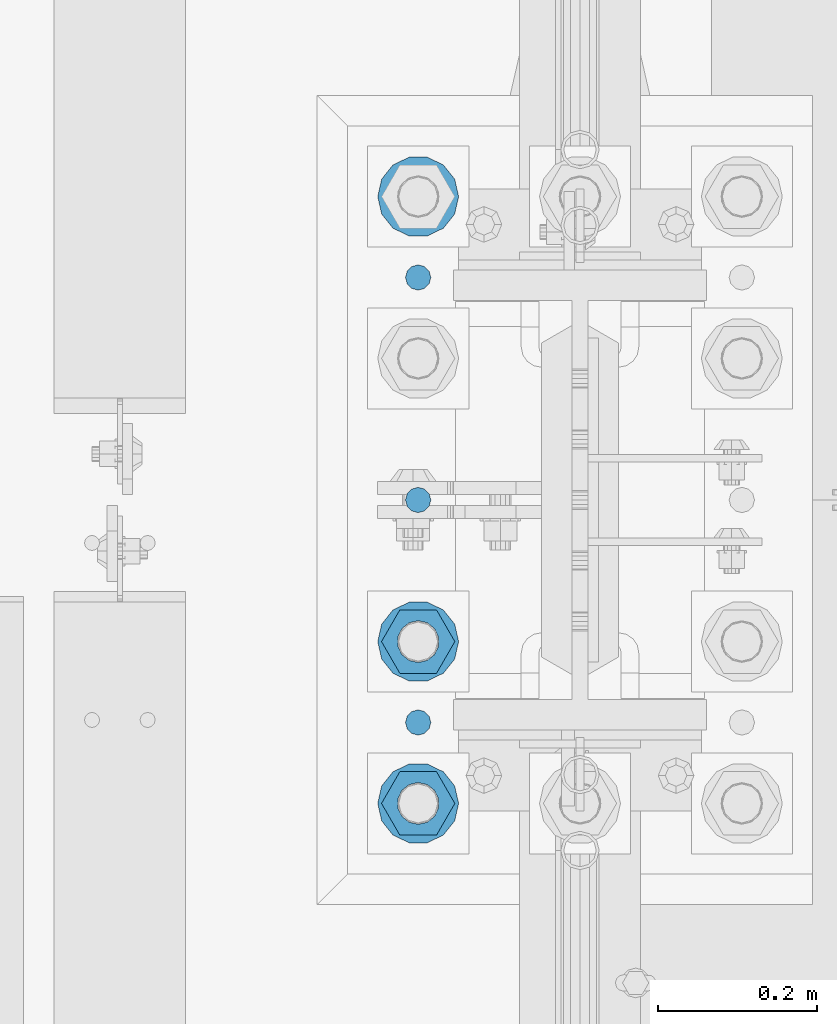
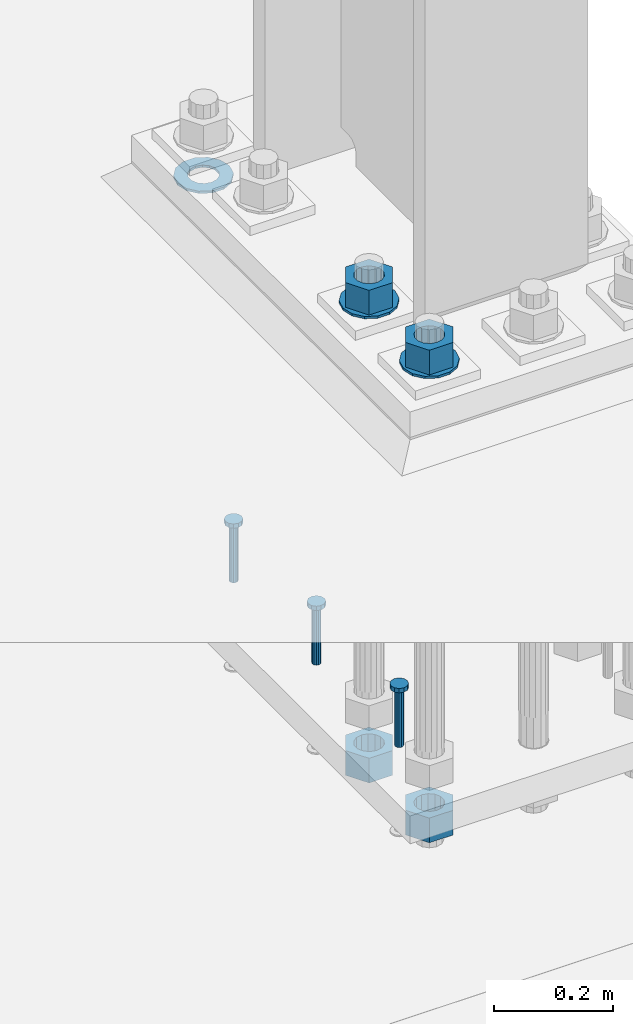
# One storey, part 838 of 1876: 10 columns, 1 element without a shape of its own.
"""IFC2X3 building model written with IfcOpenShell, lengths in millimetres."""

from ifc_helpers import new_model, si_unit, frame, origin_with_axes, place, context, subcontext, project, spatial, faceted_brep, material, type_object, element, aggregate, save


model = new_model("IFC2X3")

# Units and contexts
model_context = context("Model", 3, precision=1e-05, world=origin_with_axes())
body_context = subcontext(model_context, "Body", "Model", "MODEL_VIEW")
ifc_project = project(units=[si_unit("LENGTHUNIT", "METRE", prefix="MILLI"), si_unit("AREAUNIT", "SQUARE_METRE"), si_unit("VOLUMEUNIT", "CUBIC_METRE"), si_unit("MASSUNIT", "GRAM", prefix="KILO"), si_unit("TIMEUNIT", "SECOND"), si_unit("PLANEANGLEUNIT", "RADIAN"), si_unit("SOLIDANGLEUNIT", "STERADIAN"), si_unit("THERMODYNAMICTEMPERATUREUNIT", "DEGREE_CELSIUS"), si_unit("LUMINOUSINTENSITYUNIT", "LUMEN")], contexts=[model_context])

# Site, building, storey
site_placement = place(None, origin_with_axes())
site = spatial("IfcSite", under=ifc_project, at=site_placement, CompositionType="ELEMENT")
building_placement = place(site_placement, origin_with_axes())
building = spatial("IfcBuilding", under=site, at=building_placement, Name="Undefined", CompositionType="ELEMENT")
storey_placement = place(building_placement, origin_with_axes())
storey = spatial("IfcBuildingStorey", under=building, at=storey_placement, Name="Undefined", CompositionType="ELEMENT", Elevation=0.0)

# Assembly, columns
assembly_placement = place(storey_placement, origin_with_axes())
assembly = element("IfcElementAssembly", 1, at=assembly_placement, inside=storey, Name="TEMPLATE", AssemblyPlace="NOTDEFINED", PredefinedType="RIGID_FRAME")
ifc_material_1 = material(Name="STEEL/F436")
column_type_1 = type_object("IfcColumnType", Name="2_WASHER", PredefinedType="NOTDEFINED")
column_1_placement = place(assembly_placement, frame((7416.8, 1905.0, 38.1), z_axis=(0.0, -1.0, 0.0), x_axis=(0.0, 0.0, -1.0)))
column_1 = element("IfcColumn", 2, at=column_1_placement, type_object=column_type_1, material=ifc_material_1, Name="WASHER", ObjectType="2_WASHER", context=body_context, shape_type="Brep", body=[
    faceted_brep([(0.0, -50.7999992370605, 9.09494701772928e-13), (0.0, -45.7692178020588, -22.0412936161442), (4.7625, -45.7692178020588, -22.0412936161442), (4.7625, -50.7999992370605, 9.09494701772928e-13), (0.0, -31.6732814587394, -39.7170387128856), (4.7625, -31.6732814587394, -39.7170387128856), (0.0, -11.3040632752118, -49.5263371950259), (4.7625, -11.3040632752118, -49.5263371950259), (0.0, 11.30406327521, -49.5263371950264), (4.7625, 11.30406327521, -49.5263371950264), (0.0, 31.6732814587385, -39.7170387128867), (4.7625, 31.6732814587385, -39.7170387128867), (0.0, 45.7692178020579, -22.041293616146), (4.7625, 45.7692178020579, -22.041293616146), (0.0, 50.7999992370605, -9.09494701772928e-13), (4.7625, 50.7999992370605, -9.09494701772928e-13), (0.0, 45.7692178020588, 22.0412936161442), (4.7625, 45.7692178020588, 22.0412936161442), (0.0, 31.6732814587394, 39.7170387128856), (4.7625, 31.6732814587394, 39.7170387128856), (0.0, 11.3040632752118, 49.5263371950259), (4.7625, 11.3040632752118, 49.5263371950259), (0.0, -11.30406327521, 49.5263371950264), (4.7625, -11.30406327521, 49.5263371950264), (0.0, -31.6732814587385, 39.7170387128867), (4.7625, -31.6732814587385, 39.7170387128867), (0.0, -45.7692178020579, 22.041293616146), (4.7625, -45.7692178020579, 22.041293616146), (0.0, 0.0, 26.9869995117188), (0.0, 11.7093983825444, 24.3146012721213), (4.7625, 11.7093983825444, 24.3146012721213), (4.7625, 0.0, 26.9869995117188), (0.0, 21.0996520289491, 16.8262864224157), (4.7625, 21.0996520289491, 16.8262864224157), (0.0, 26.3108629296712, 6.00524193584533), (4.7625, 26.3108629296712, 6.00524193584533), (0.0, 26.3108629296712, -6.00524193584533), (4.7625, 26.3108629296712, -6.00524193584533), (0.0, 21.0996520289491, -16.8262864224157), (4.7625, 21.0996520289491, -16.8262864224157), (0.0, 11.7093983825444, -24.3146012721213), (4.7625, 11.7093983825444, -24.3146012721213), (0.0, 0.0, -26.9869995117188), (4.7625, 0.0, -26.9869995117188), (0.0, -11.7093983825444, -24.3146012721213), (4.7625, -11.7093983825444, -24.3146012721213), (0.0, -21.0996520289491, -16.8262864224157), (4.7625, -21.0996520289491, -16.8262864224157), (0.0, -26.3108629296712, -6.00524193584533), (4.7625, -26.3108629296712, -6.00524193584533), (0.0, -26.3108629296712, 6.00524193584533), (4.7625, -26.3108629296712, 6.00524193584533), (0.0, -21.0996520289491, 16.8262864224157), (4.7625, -21.0996520289491, 16.8262864224157), (0.0, -11.7093983825444, 24.3146012721213), (4.7625, -11.7093983825444, 24.3146012721213)], [[[0, 1, 2, 3]], [[1, 4, 5, 2]], [[4, 6, 7, 5]], [[6, 8, 9, 7]], [[8, 10, 11, 9]], [[10, 12, 13, 11]], [[12, 14, 15, 13]], [[14, 16, 17, 15]], [[16, 18, 19, 17]], [[18, 20, 21, 19]], [[20, 22, 23, 21]], [[22, 24, 25, 23]], [[24, 26, 27, 25]], [[26, 0, 3, 27]], [[28, 29, 30, 31]], [[29, 32, 33, 30]], [[32, 34, 35, 33]], [[34, 36, 37, 35]], [[36, 38, 39, 37]], [[38, 40, 41, 39]], [[40, 42, 43, 41]], [[42, 44, 45, 43]], [[44, 46, 47, 45]], [[46, 48, 49, 47]], [[48, 50, 51, 49]], [[50, 52, 53, 51]], [[52, 54, 55, 53]], [[54, 28, 31, 55]], [[5, 7, 9, 11, 13, 15, 17, 19, 21, 23, 25, 27, 3, 2], [33, 35, 37, 39, 41, 43, 45, 47, 49, 51, 53, 55, 31, 30]], [[26, 24, 22, 20, 18, 16, 14, 12, 10, 8, 6, 4, 1, 0], [54, 52, 50, 48, 46, 44, 42, 40, 38, 36, 34, 32, 29, 28]]]),
])
column_2_placement = place(assembly_placement, frame((7416.8, 1143.0, 119.0625), z_axis=(0.0, -1.0, 0.0), x_axis=(0.0, 0.0, -1.0)))
column_2 = element("IfcColumn", 3, at=column_2_placement, type_object=column_type_1, material=ifc_material_1, Name="WASHER", ObjectType="2_WASHER", context=body_context, shape_type="Brep", body=[
    faceted_brep([(0.0, -50.7999992370605, 9.09494701772928e-13), (0.0, -45.7692178020588, -22.0412936161442), (4.7625, -45.7692178020588, -22.0412936161442), (4.7625, -50.7999992370605, 9.09494701772928e-13), (0.0, -31.6732814587394, -39.7170387128856), (4.7625, -31.6732814587394, -39.7170387128856), (0.0, -11.3040632752118, -49.5263371950259), (4.7625, -11.3040632752118, -49.5263371950259), (0.0, 11.30406327521, -49.5263371950264), (4.7625, 11.30406327521, -49.5263371950264), (0.0, 31.6732814587385, -39.7170387128867), (4.7625, 31.6732814587385, -39.7170387128867), (0.0, 45.7692178020579, -22.041293616146), (4.7625, 45.7692178020579, -22.041293616146), (0.0, 50.7999992370605, -9.09494701772928e-13), (4.7625, 50.7999992370605, -9.09494701772928e-13), (0.0, 45.7692178020588, 22.0412936161442), (4.7625, 45.7692178020588, 22.0412936161442), (0.0, 31.6732814587394, 39.7170387128856), (4.7625, 31.6732814587394, 39.7170387128856), (0.0, 11.3040632752118, 49.5263371950259), (4.7625, 11.3040632752118, 49.5263371950259), (0.0, -11.30406327521, 49.5263371950264), (4.7625, -11.30406327521, 49.5263371950264), (0.0, -31.6732814587385, 39.7170387128867), (4.7625, -31.6732814587385, 39.7170387128867), (0.0, -45.7692178020579, 22.041293616146), (4.7625, -45.7692178020579, 22.041293616146), (0.0, 0.0, 26.9869995117188), (0.0, 11.7093983825444, 24.3146012721213), (4.7625, 11.7093983825444, 24.3146012721213), (4.7625, 0.0, 26.9869995117188), (0.0, 21.0996520289491, 16.8262864224157), (4.7625, 21.0996520289491, 16.8262864224157), (0.0, 26.3108629296712, 6.00524193584533), (4.7625, 26.3108629296712, 6.00524193584533), (0.0, 26.3108629296712, -6.00524193584533), (4.7625, 26.3108629296712, -6.00524193584533), (0.0, 21.0996520289491, -16.8262864224157), (4.7625, 21.0996520289491, -16.8262864224157), (0.0, 11.7093983825444, -24.3146012721213), (4.7625, 11.7093983825444, -24.3146012721213), (0.0, 0.0, -26.9869995117188), (4.7625, 0.0, -26.9869995117188), (0.0, -11.7093983825444, -24.3146012721213), (4.7625, -11.7093983825444, -24.3146012721213), (0.0, -21.0996520289491, -16.8262864224157), (4.7625, -21.0996520289491, -16.8262864224157), (0.0, -26.3108629296712, -6.00524193584533), (4.7625, -26.3108629296712, -6.00524193584533), (0.0, -26.3108629296712, 6.00524193584533), (4.7625, -26.3108629296712, 6.00524193584533), (0.0, -21.0996520289491, 16.8262864224157), (4.7625, -21.0996520289491, 16.8262864224157), (0.0, -11.7093983825444, 24.3146012721213), (4.7625, -11.7093983825444, 24.3146012721213)], [[[0, 1, 2, 3]], [[1, 4, 5, 2]], [[4, 6, 7, 5]], [[6, 8, 9, 7]], [[8, 10, 11, 9]], [[10, 12, 13, 11]], [[12, 14, 15, 13]], [[14, 16, 17, 15]], [[16, 18, 19, 17]], [[18, 20, 21, 19]], [[20, 22, 23, 21]], [[22, 24, 25, 23]], [[24, 26, 27, 25]], [[26, 0, 3, 27]], [[28, 29, 30, 31]], [[29, 32, 33, 30]], [[32, 34, 35, 33]], [[34, 36, 37, 35]], [[36, 38, 39, 37]], [[38, 40, 41, 39]], [[40, 42, 43, 41]], [[42, 44, 45, 43]], [[44, 46, 47, 45]], [[46, 48, 49, 47]], [[48, 50, 51, 49]], [[50, 52, 53, 51]], [[52, 54, 55, 53]], [[54, 28, 31, 55]], [[5, 7, 9, 11, 13, 15, 17, 19, 21, 23, 25, 27, 3, 2], [33, 35, 37, 39, 41, 43, 45, 47, 49, 51, 53, 55, 31, 30]], [[26, 24, 22, 20, 18, 16, 14, 12, 10, 8, 6, 4, 1, 0], [54, 52, 50, 48, 46, 44, 42, 40, 38, 36, 34, 32, 29, 28]]]),
])
column_3_placement = place(assembly_placement, frame((7416.8, 1346.2, 119.0625), z_axis=(0.0, -1.0, 0.0), x_axis=(0.0, 0.0, -1.0)))
column_3 = element("IfcColumn", 4, at=column_3_placement, type_object=column_type_1, material=ifc_material_1, Name="WASHER", ObjectType="2_WASHER", context=body_context, shape_type="Brep", body=[
    faceted_brep([(0.0, -50.7999992370605, 9.09494701772928e-13), (0.0, -45.7692178020588, -22.0412936161442), (4.7625, -45.7692178020588, -22.0412936161442), (4.7625, -50.7999992370605, 9.09494701772928e-13), (0.0, -31.6732814587394, -39.7170387128856), (4.7625, -31.6732814587394, -39.7170387128856), (0.0, -11.3040632752118, -49.5263371950259), (4.7625, -11.3040632752118, -49.5263371950259), (0.0, 11.30406327521, -49.5263371950264), (4.7625, 11.30406327521, -49.5263371950264), (0.0, 31.6732814587385, -39.7170387128867), (4.7625, 31.6732814587385, -39.7170387128867), (0.0, 45.7692178020579, -22.041293616146), (4.7625, 45.7692178020579, -22.041293616146), (0.0, 50.7999992370605, -9.09494701772928e-13), (4.7625, 50.7999992370605, -9.09494701772928e-13), (0.0, 45.7692178020588, 22.0412936161442), (4.7625, 45.7692178020588, 22.0412936161442), (0.0, 31.6732814587394, 39.7170387128856), (4.7625, 31.6732814587394, 39.7170387128856), (0.0, 11.3040632752118, 49.5263371950259), (4.7625, 11.3040632752118, 49.5263371950259), (0.0, -11.30406327521, 49.5263371950264), (4.7625, -11.30406327521, 49.5263371950264), (0.0, -31.6732814587385, 39.7170387128867), (4.7625, -31.6732814587385, 39.7170387128867), (0.0, -45.7692178020579, 22.041293616146), (4.7625, -45.7692178020579, 22.041293616146), (0.0, 0.0, 26.9869995117188), (0.0, 11.7093983825444, 24.3146012721213), (4.7625, 11.7093983825444, 24.3146012721213), (4.7625, 0.0, 26.9869995117188), (0.0, 21.0996520289491, 16.8262864224157), (4.7625, 21.0996520289491, 16.8262864224157), (0.0, 26.3108629296712, 6.00524193584533), (4.7625, 26.3108629296712, 6.00524193584533), (0.0, 26.3108629296712, -6.00524193584533), (4.7625, 26.3108629296712, -6.00524193584533), (0.0, 21.0996520289491, -16.8262864224157), (4.7625, 21.0996520289491, -16.8262864224157), (0.0, 11.7093983825444, -24.3146012721213), (4.7625, 11.7093983825444, -24.3146012721213), (0.0, 0.0, -26.9869995117188), (4.7625, 0.0, -26.9869995117188), (0.0, -11.7093983825444, -24.3146012721213), (4.7625, -11.7093983825444, -24.3146012721213), (0.0, -21.0996520289491, -16.8262864224157), (4.7625, -21.0996520289491, -16.8262864224157), (0.0, -26.3108629296712, -6.00524193584533), (4.7625, -26.3108629296712, -6.00524193584533), (0.0, -26.3108629296712, 6.00524193584533), (4.7625, -26.3108629296712, 6.00524193584533), (0.0, -21.0996520289491, 16.8262864224157), (4.7625, -21.0996520289491, 16.8262864224157), (0.0, -11.7093983825444, 24.3146012721213), (4.7625, -11.7093983825444, 24.3146012721213)], [[[0, 1, 2, 3]], [[1, 4, 5, 2]], [[4, 6, 7, 5]], [[6, 8, 9, 7]], [[8, 10, 11, 9]], [[10, 12, 13, 11]], [[12, 14, 15, 13]], [[14, 16, 17, 15]], [[16, 18, 19, 17]], [[18, 20, 21, 19]], [[20, 22, 23, 21]], [[22, 24, 25, 23]], [[24, 26, 27, 25]], [[26, 0, 3, 27]], [[28, 29, 30, 31]], [[29, 32, 33, 30]], [[32, 34, 35, 33]], [[34, 36, 37, 35]], [[36, 38, 39, 37]], [[38, 40, 41, 39]], [[40, 42, 43, 41]], [[42, 44, 45, 43]], [[44, 46, 47, 45]], [[46, 48, 49, 47]], [[48, 50, 51, 49]], [[50, 52, 53, 51]], [[52, 54, 55, 53]], [[54, 28, 31, 55]], [[5, 7, 9, 11, 13, 15, 17, 19, 21, 23, 25, 27, 3, 2], [33, 35, 37, 39, 41, 43, 45, 47, 49, 51, 53, 55, 31, 30]], [[26, 24, 22, 20, 18, 16, 14, 12, 10, 8, 6, 4, 1, 0], [54, 52, 50, 48, 46, 44, 42, 40, 38, 36, 34, 32, 29, 28]]]),
])
ifc_material_2 = material(Name="STEEL/A108")
column_type_2 = type_object("IfcColumnType", Name="5/8-DIA_HEADED ANCHOR STUD", PredefinedType="NOTDEFINED")
column_4_placement = place(assembly_placement, frame((7416.8, 1803.4, -736.6), z_axis=(1.0, 0.0, 0.0), x_axis=(0.0, 0.0, 1.0)))
column_4 = element("IfcColumn", 5, at=column_4_placement, type_object=column_type_2, material=ifc_material_2, Name="HEADED ANCHOR STUD", ObjectType="5/8-DIA_HEADED ANCHOR STUD", context=body_context, shape_type="Brep", body=[
    faceted_brep([(0.0, -7.94000005722046, 0.0), (0.0, -6.86999988555908, -3.97000002861023), (116.84, -6.86999988555908, -3.97000002861023), (116.84, -7.94000005722046, 0.0), (0.0, -3.97000002861023, -6.86999988555908), (116.84, -3.97000002861023, -6.86999988555908), (0.0, 0.0, -7.94000005722046), (116.84, 0.0, -7.94000005722046), (0.0, 3.97000002861023, -6.86999988555908), (116.84, 3.97000002861023, -6.86999988555908), (0.0, 6.86999988555908, -3.97000002861023), (116.84, 6.86999988555908, -3.97000002861023), (0.0, 7.94000005722046, 0.0), (116.84, 7.94000005722046, 0.0), (0.0, 6.86999988555908, 3.97000002861023), (116.84, 6.86999988555908, 3.97000002861023), (0.0, 3.97000002861023, 6.86999988555908), (116.84, 3.97000002861023, 6.86999988555908), (0.0, 0.0, 7.94000005722046), (116.84, 0.0, 7.94000005722046), (0.0, -3.97000002861023, 6.86999988555908), (116.84, -3.97000002861023, 6.86999988555908), (0.0, -6.86999988555908, 3.97000002861023), (116.84, -6.86999988555908, 3.97000002861023), (118.11, -13.75, -7.94000005722046), (118.11, -15.8800001144409, 0.0), (118.11, -7.94000005722046, -13.75), (118.11, 0.0, -15.8800001144409), (118.11, 7.94000005722046, -13.75), (118.11, 13.75, -7.94000005722046), (118.11, 15.8800001144409, 0.0), (118.11, 13.75, 7.94000005722046), (118.11, 7.94000005722046, 13.75), (118.11, 0.0, 15.8800001144409), (118.11, -7.94000005722046, 13.75), (118.11, -13.75, 7.94000005722046), (127.0, -13.75, -7.94000005722046), (127.0, -15.8800001144409, 0.0), (127.0, -7.94000005722046, -13.75), (127.0, 0.0, -15.8800001144409), (127.0, 7.94000005722046, -13.75), (127.0, 13.75, -7.94000005722046), (127.0, 15.8800001144409, 0.0), (127.0, 13.75, 7.94000005722046), (127.0, 7.94000005722046, 13.75), (127.0, 0.0, 15.8800001144409), (127.0, -7.94000005722046, 13.75), (127.0, -13.75, 7.94000005722046)], [[[0, 1, 2, 3]], [[1, 4, 5, 2]], [[4, 6, 7, 5]], [[6, 8, 9, 7]], [[8, 10, 11, 9]], [[10, 12, 13, 11]], [[12, 14, 15, 13]], [[14, 16, 17, 15]], [[16, 18, 19, 17]], [[18, 20, 21, 19]], [[20, 22, 23, 21]], [[22, 0, 3, 23]], [[22, 20, 18, 16, 14, 12, 10, 8, 6, 4, 1, 0]], [[3, 2, 24, 25]], [[2, 5, 26, 24]], [[5, 7, 27, 26]], [[7, 9, 28, 27]], [[9, 11, 29, 28]], [[11, 13, 30, 29]], [[13, 15, 31, 30]], [[15, 17, 32, 31]], [[17, 19, 33, 32]], [[19, 21, 34, 33]], [[21, 23, 35, 34]], [[23, 3, 25, 35]], [[25, 24, 36, 37]], [[24, 26, 38, 36]], [[26, 27, 39, 38]], [[27, 28, 40, 39]], [[28, 29, 41, 40]], [[29, 30, 42, 41]], [[30, 31, 43, 42]], [[31, 32, 44, 43]], [[32, 33, 45, 44]], [[33, 34, 46, 45]], [[34, 35, 47, 46]], [[35, 25, 37, 47]], [[38, 39, 40, 41, 42, 43, 44, 45, 46, 47, 37, 36]]]),
])
column_5_placement = place(assembly_placement, frame((7416.8, 1244.6, -736.6), z_axis=(1.0, 0.0, 0.0), x_axis=(0.0, 0.0, 1.0)))
column_5 = element("IfcColumn", 6, at=column_5_placement, type_object=column_type_2, material=ifc_material_2, Name="HEADED ANCHOR STUD", ObjectType="5/8-DIA_HEADED ANCHOR STUD", context=body_context, shape_type="Brep", body=[
    faceted_brep([(0.0, -7.94000005722046, 0.0), (0.0, -6.86999988555908, -3.97000002861023), (116.84, -6.86999988555908, -3.97000002861023), (116.84, -7.94000005722046, 0.0), (0.0, -3.97000002861023, -6.86999988555908), (116.84, -3.97000002861023, -6.86999988555908), (0.0, 0.0, -7.94000005722046), (116.84, 0.0, -7.94000005722046), (0.0, 3.97000002861023, -6.86999988555908), (116.84, 3.97000002861023, -6.86999988555908), (0.0, 6.86999988555908, -3.97000002861023), (116.84, 6.86999988555908, -3.97000002861023), (0.0, 7.94000005722046, 0.0), (116.84, 7.94000005722046, 0.0), (0.0, 6.86999988555908, 3.97000002861023), (116.84, 6.86999988555908, 3.97000002861023), (0.0, 3.97000002861023, 6.86999988555908), (116.84, 3.97000002861023, 6.86999988555908), (0.0, 0.0, 7.94000005722046), (116.84, 0.0, 7.94000005722046), (0.0, -3.97000002861023, 6.86999988555908), (116.84, -3.97000002861023, 6.86999988555908), (0.0, -6.86999988555908, 3.97000002861023), (116.84, -6.86999988555908, 3.97000002861023), (118.11, -13.75, -7.94000005722046), (118.11, -15.8800001144409, 0.0), (118.11, -7.94000005722046, -13.75), (118.11, 0.0, -15.8800001144409), (118.11, 7.94000005722046, -13.75), (118.11, 13.75, -7.94000005722046), (118.11, 15.8800001144409, 0.0), (118.11, 13.75, 7.94000005722046), (118.11, 7.94000005722046, 13.75), (118.11, 0.0, 15.8800001144409), (118.11, -7.94000005722046, 13.75), (118.11, -13.75, 7.94000005722046), (127.0, -13.75, -7.94000005722046), (127.0, -15.8800001144409, 0.0), (127.0, -7.94000005722046, -13.75), (127.0, 0.0, -15.8800001144409), (127.0, 7.94000005722046, -13.75), (127.0, 13.75, -7.94000005722046), (127.0, 15.8800001144409, 0.0), (127.0, 13.75, 7.94000005722046), (127.0, 7.94000005722046, 13.75), (127.0, 0.0, 15.8800001144409), (127.0, -7.94000005722046, 13.75), (127.0, -13.75, 7.94000005722046)], [[[0, 1, 2, 3]], [[1, 4, 5, 2]], [[4, 6, 7, 5]], [[6, 8, 9, 7]], [[8, 10, 11, 9]], [[10, 12, 13, 11]], [[12, 14, 15, 13]], [[14, 16, 17, 15]], [[16, 18, 19, 17]], [[18, 20, 21, 19]], [[20, 22, 23, 21]], [[22, 0, 3, 23]], [[22, 20, 18, 16, 14, 12, 10, 8, 6, 4, 1, 0]], [[3, 2, 24, 25]], [[2, 5, 26, 24]], [[5, 7, 27, 26]], [[7, 9, 28, 27]], [[9, 11, 29, 28]], [[11, 13, 30, 29]], [[13, 15, 31, 30]], [[15, 17, 32, 31]], [[17, 19, 33, 32]], [[19, 21, 34, 33]], [[21, 23, 35, 34]], [[23, 3, 25, 35]], [[25, 24, 36, 37]], [[24, 26, 38, 36]], [[26, 27, 39, 38]], [[27, 28, 40, 39]], [[28, 29, 41, 40]], [[29, 30, 42, 41]], [[30, 31, 43, 42]], [[31, 32, 44, 43]], [[32, 33, 45, 44]], [[33, 34, 46, 45]], [[34, 35, 47, 46]], [[35, 25, 37, 47]], [[38, 39, 40, 41, 42, 43, 44, 45, 46, 47, 37, 36]]]),
])
column_6_placement = place(assembly_placement, frame((7416.8, 1524.0, -736.6), z_axis=(1.0, 0.0, 0.0), x_axis=(0.0, 0.0, 1.0)))
column_6 = element("IfcColumn", 7, at=column_6_placement, type_object=column_type_2, material=ifc_material_2, Name="HEADED ANCHOR STUD", ObjectType="5/8-DIA_HEADED ANCHOR STUD", context=body_context, shape_type="Brep", body=[
    faceted_brep([(0.0, -7.94000005722046, 0.0), (0.0, -6.86999988555908, -3.97000002861023), (116.84, -6.86999988555908, -3.97000002861023), (116.84, -7.94000005722046, 0.0), (0.0, -3.97000002861023, -6.86999988555908), (116.84, -3.97000002861023, -6.86999988555908), (0.0, 0.0, -7.94000005722046), (116.84, 0.0, -7.94000005722046), (0.0, 3.97000002861023, -6.86999988555908), (116.84, 3.97000002861023, -6.86999988555908), (0.0, 6.86999988555908, -3.97000002861023), (116.84, 6.86999988555908, -3.97000002861023), (0.0, 7.94000005722046, 0.0), (116.84, 7.94000005722046, 0.0), (0.0, 6.86999988555908, 3.97000002861023), (116.84, 6.86999988555908, 3.97000002861023), (0.0, 3.97000002861023, 6.86999988555908), (116.84, 3.97000002861023, 6.86999988555908), (0.0, 0.0, 7.94000005722046), (116.84, 0.0, 7.94000005722046), (0.0, -3.97000002861023, 6.86999988555908), (116.84, -3.97000002861023, 6.86999988555908), (0.0, -6.86999988555908, 3.97000002861023), (116.84, -6.86999988555908, 3.97000002861023), (118.11, -13.75, -7.94000005722046), (118.11, -15.8800001144409, 0.0), (118.11, -7.94000005722046, -13.75), (118.11, 0.0, -15.8800001144409), (118.11, 7.94000005722046, -13.75), (118.11, 13.75, -7.94000005722046), (118.11, 15.8800001144409, 0.0), (118.11, 13.75, 7.94000005722046), (118.11, 7.94000005722046, 13.75), (118.11, 0.0, 15.8800001144409), (118.11, -7.94000005722046, 13.75), (118.11, -13.75, 7.94000005722046), (127.0, -13.75, -7.94000005722046), (127.0, -15.8800001144409, 0.0), (127.0, -7.94000005722046, -13.75), (127.0, 0.0, -15.8800001144409), (127.0, 7.94000005722046, -13.75), (127.0, 13.75, -7.94000005722046), (127.0, 15.8800001144409, 0.0), (127.0, 13.75, 7.94000005722046), (127.0, 7.94000005722046, 13.75), (127.0, 0.0, 15.8800001144409), (127.0, -7.94000005722046, 13.75), (127.0, -13.75, 7.94000005722046)], [[[0, 1, 2, 3]], [[1, 4, 5, 2]], [[4, 6, 7, 5]], [[6, 8, 9, 7]], [[8, 10, 11, 9]], [[10, 12, 13, 11]], [[12, 14, 15, 13]], [[14, 16, 17, 15]], [[16, 18, 19, 17]], [[18, 20, 21, 19]], [[20, 22, 23, 21]], [[22, 0, 3, 23]], [[22, 20, 18, 16, 14, 12, 10, 8, 6, 4, 1, 0]], [[3, 2, 24, 25]], [[2, 5, 26, 24]], [[5, 7, 27, 26]], [[7, 9, 28, 27]], [[9, 11, 29, 28]], [[11, 13, 30, 29]], [[13, 15, 31, 30]], [[15, 17, 32, 31]], [[17, 19, 33, 32]], [[19, 21, 34, 33]], [[21, 23, 35, 34]], [[23, 3, 25, 35]], [[25, 24, 36, 37]], [[24, 26, 38, 36]], [[26, 27, 39, 38]], [[27, 28, 40, 39]], [[28, 29, 41, 40]], [[29, 30, 42, 41]], [[30, 31, 43, 42]], [[31, 32, 44, 43]], [[32, 33, 45, 44]], [[33, 34, 46, 45]], [[34, 35, 47, 46]], [[35, 25, 37, 47]], [[38, 39, 40, 41, 42, 43, 44, 45, 46, 47, 37, 36]]]),
])
ifc_material_3 = material(Name="STEEL/A563")
column_type_3 = type_object("IfcColumnType", Name="2_HEAVY_HEX_NUT", PredefinedType="NOTDEFINED")
column_7_placement = place(assembly_placement, frame((7416.8, 1143.0, 169.8625), z_axis=(0.0, -1.0, 0.0), x_axis=(0.0, 0.0, -1.0)))
column_7 = element("IfcColumn", 8, at=column_7_placement, type_object=column_type_3, material=ifc_material_3, Name="NUT", ObjectType="2_HEAVY_HEX_NUT", context=body_context, shape_type="Brep", body=[
    faceted_brep([(0.0, -46.0369987487793, 9.09494701772928e-13), (0.0, -23.0184993743896, -39.869213104248), (50.8, -23.0184993743896, -39.869213104248), (50.8, -46.0369987487793, 9.09494701772928e-13), (0.0, 23.0184993743896, -39.869213104248), (50.8, 23.0184993743896, -39.869213104248), (0.0, 46.0369987487793, -9.09494701772928e-13), (50.8, 46.0369987487793, -9.09494701772928e-13), (0.0, 23.0184993743896, 39.869213104248), (50.8, 23.0184993743896, 39.869213104248), (0.0, -23.0184993743896, 39.869213104248), (50.8, -23.0184993743896, 39.869213104248), (0.0, 0.0, 26.1940002441406), (0.0, 11.3650617044514, 23.5999013092769), (50.8, 11.3650617044513, 23.5999013092771), (50.8, 0.0, 26.1940002441406), (0.0, 20.4791109456437, 16.3316083006703), (50.8, 20.4791109456439, 16.3316083006703), (0.0, 25.5370200498346, 5.82867859874477), (50.8, 25.5370200498343, 5.82867859874455), (0.0, 25.5370200498346, -5.82867859874477), (50.8, 25.5370200498343, -5.82867859874455), (0.0, 20.4791109456437, -16.3316083006703), (50.8, 20.4791109456439, -16.3316083006703), (0.0, 11.3650617044514, -23.5999013092769), (50.8, 11.3650617044514, -23.5999013092771), (0.0, 0.0, -26.1940002441406), (50.8, 0.0, -26.1940002441406), (0.0, -11.3650617044514, -23.5999013092769), (50.8, -11.3650617044513, -23.5999013092771), (0.0, -20.4791109456437, -16.3316083006703), (50.8, -20.4791109456439, -16.3316083006703), (0.0, -25.5370200498346, -5.82867859874477), (50.8, -25.5370200498343, -5.82867859874455), (0.0, -25.5370200498346, 5.82867859874477), (50.8, -25.5370200498343, 5.82867859874455), (0.0, -20.4791109456437, 16.3316083006703), (50.8, -20.4791109456439, 16.3316083006703), (0.0, -11.3650617044514, 23.5999013092769), (50.8, -11.3650617044514, 23.5999013092771)], [[[0, 1, 2, 3]], [[1, 4, 5, 2]], [[4, 6, 7, 5]], [[6, 8, 9, 7]], [[8, 10, 11, 9]], [[10, 0, 3, 11]], [[12, 13, 14, 15]], [[13, 16, 17, 14]], [[16, 18, 19, 17]], [[18, 20, 21, 19]], [[20, 22, 23, 21]], [[22, 24, 25, 23]], [[24, 26, 27, 25]], [[26, 28, 29, 27]], [[28, 30, 31, 29]], [[30, 32, 33, 31]], [[32, 34, 35, 33]], [[34, 36, 37, 35]], [[36, 38, 39, 37]], [[38, 12, 15, 39]], [[5, 7, 9, 11, 3, 2], [17, 19, 21, 23, 25, 27, 29, 31, 33, 35, 37, 39, 15, 14]], [[10, 8, 6, 4, 1, 0], [38, 36, 34, 32, 30, 28, 26, 24, 22, 20, 18, 16, 13, 12]]]),
])
column_8_placement = place(assembly_placement, frame((7416.8, 1143.0, -793.75), z_axis=(0.0, -1.0, 0.0), x_axis=(0.0, 0.0, -1.0)))
column_8 = element("IfcColumn", 9, at=column_8_placement, type_object=column_type_3, material=ifc_material_3, Name="NUT", ObjectType="2_HEAVY_HEX_NUT", context=body_context, shape_type="Brep", body=[
    faceted_brep([(0.0, -46.0369987487793, 9.09494701772928e-13), (0.0, -23.0184993743896, -39.869213104248), (50.8, -23.0184993743896, -39.869213104248), (50.8, -46.0369987487793, 9.09494701772928e-13), (0.0, 23.0184993743896, -39.869213104248), (50.8, 23.0184993743896, -39.869213104248), (0.0, 46.0369987487793, -9.09494701772928e-13), (50.8, 46.0369987487793, -9.09494701772928e-13), (0.0, 23.0184993743896, 39.869213104248), (50.8, 23.0184993743896, 39.869213104248), (0.0, -23.0184993743896, 39.869213104248), (50.8, -23.0184993743896, 39.869213104248), (0.0, 0.0, 26.1940002441406), (0.0, 11.3650617044514, 23.5999013092769), (50.8, 11.3650617044513, 23.5999013092771), (50.8, 0.0, 26.1940002441406), (0.0, 20.4791109456437, 16.3316083006703), (50.8, 20.4791109456439, 16.3316083006703), (0.0, 25.5370200498346, 5.82867859874477), (50.8, 25.5370200498343, 5.82867859874455), (0.0, 25.5370200498346, -5.82867859874477), (50.8, 25.5370200498343, -5.82867859874455), (0.0, 20.4791109456437, -16.3316083006703), (50.8, 20.4791109456439, -16.3316083006703), (0.0, 11.3650617044514, -23.5999013092769), (50.8, 11.3650617044514, -23.5999013092771), (0.0, 0.0, -26.1940002441406), (50.8, 0.0, -26.1940002441406), (0.0, -11.3650617044514, -23.5999013092769), (50.8, -11.3650617044513, -23.5999013092771), (0.0, -20.4791109456437, -16.3316083006703), (50.8, -20.4791109456439, -16.3316083006703), (0.0, -25.5370200498346, -5.82867859874477), (50.8, -25.5370200498343, -5.82867859874455), (0.0, -25.5370200498346, 5.82867859874477), (50.8, -25.5370200498343, 5.82867859874455), (0.0, -20.4791109456437, 16.3316083006703), (50.8, -20.4791109456439, 16.3316083006703), (0.0, -11.3650617044514, 23.5999013092769), (50.8, -11.3650617044514, 23.5999013092771)], [[[0, 1, 2, 3]], [[1, 4, 5, 2]], [[4, 6, 7, 5]], [[6, 8, 9, 7]], [[8, 10, 11, 9]], [[10, 0, 3, 11]], [[12, 13, 14, 15]], [[13, 16, 17, 14]], [[16, 18, 19, 17]], [[18, 20, 21, 19]], [[20, 22, 23, 21]], [[22, 24, 25, 23]], [[24, 26, 27, 25]], [[26, 28, 29, 27]], [[28, 30, 31, 29]], [[30, 32, 33, 31]], [[32, 34, 35, 33]], [[34, 36, 37, 35]], [[36, 38, 39, 37]], [[38, 12, 15, 39]], [[5, 7, 9, 11, 3, 2], [17, 19, 21, 23, 25, 27, 29, 31, 33, 35, 37, 39, 15, 14]], [[10, 8, 6, 4, 1, 0], [38, 36, 34, 32, 30, 28, 26, 24, 22, 20, 18, 16, 13, 12]]]),
])
column_9_placement = place(assembly_placement, frame((7416.8, 1346.2, 169.8625), z_axis=(0.0, -1.0, 0.0), x_axis=(0.0, 0.0, -1.0)))
column_9 = element("IfcColumn", 10, at=column_9_placement, type_object=column_type_3, material=ifc_material_3, Name="NUT", ObjectType="2_HEAVY_HEX_NUT", context=body_context, shape_type="Brep", body=[
    faceted_brep([(0.0, -46.0369987487793, 9.09494701772928e-13), (0.0, -23.0184993743896, -39.869213104248), (50.8, -23.0184993743896, -39.869213104248), (50.8, -46.0369987487793, 9.09494701772928e-13), (0.0, 23.0184993743896, -39.869213104248), (50.8, 23.0184993743896, -39.869213104248), (0.0, 46.0369987487793, -9.09494701772928e-13), (50.8, 46.0369987487793, -9.09494701772928e-13), (0.0, 23.0184993743896, 39.869213104248), (50.8, 23.0184993743896, 39.869213104248), (0.0, -23.0184993743896, 39.869213104248), (50.8, -23.0184993743896, 39.869213104248), (0.0, 0.0, 26.1940002441406), (0.0, 11.3650617044514, 23.5999013092769), (50.8, 11.3650617044513, 23.5999013092771), (50.8, 0.0, 26.1940002441406), (0.0, 20.4791109456437, 16.3316083006703), (50.8, 20.4791109456439, 16.3316083006703), (0.0, 25.5370200498346, 5.82867859874477), (50.8, 25.5370200498343, 5.82867859874455), (0.0, 25.5370200498346, -5.82867859874477), (50.8, 25.5370200498343, -5.82867859874455), (0.0, 20.4791109456437, -16.3316083006703), (50.8, 20.4791109456439, -16.3316083006703), (0.0, 11.3650617044514, -23.5999013092769), (50.8, 11.3650617044514, -23.5999013092771), (0.0, 0.0, -26.1940002441406), (50.8, 0.0, -26.1940002441406), (0.0, -11.3650617044514, -23.5999013092769), (50.8, -11.3650617044513, -23.5999013092771), (0.0, -20.4791109456437, -16.3316083006703), (50.8, -20.4791109456439, -16.3316083006703), (0.0, -25.5370200498346, -5.82867859874477), (50.8, -25.5370200498343, -5.82867859874455), (0.0, -25.5370200498346, 5.82867859874477), (50.8, -25.5370200498343, 5.82867859874455), (0.0, -20.4791109456437, 16.3316083006703), (50.8, -20.4791109456439, 16.3316083006703), (0.0, -11.3650617044514, 23.5999013092769), (50.8, -11.3650617044514, 23.5999013092771)], [[[0, 1, 2, 3]], [[1, 4, 5, 2]], [[4, 6, 7, 5]], [[6, 8, 9, 7]], [[8, 10, 11, 9]], [[10, 0, 3, 11]], [[12, 13, 14, 15]], [[13, 16, 17, 14]], [[16, 18, 19, 17]], [[18, 20, 21, 19]], [[20, 22, 23, 21]], [[22, 24, 25, 23]], [[24, 26, 27, 25]], [[26, 28, 29, 27]], [[28, 30, 31, 29]], [[30, 32, 33, 31]], [[32, 34, 35, 33]], [[34, 36, 37, 35]], [[36, 38, 39, 37]], [[38, 12, 15, 39]], [[5, 7, 9, 11, 3, 2], [17, 19, 21, 23, 25, 27, 29, 31, 33, 35, 37, 39, 15, 14]], [[10, 8, 6, 4, 1, 0], [38, 36, 34, 32, 30, 28, 26, 24, 22, 20, 18, 16, 13, 12]]]),
])
column_10_placement = place(assembly_placement, frame((7416.8, 1346.2, -793.75), z_axis=(0.0, -1.0, 0.0), x_axis=(0.0, 0.0, -1.0)))
column_10 = element("IfcColumn", 11, at=column_10_placement, type_object=column_type_3, material=ifc_material_3, Name="NUT", ObjectType="2_HEAVY_HEX_NUT", context=body_context, shape_type="Brep", body=[
    faceted_brep([(0.0, -46.0369987487793, 9.09494701772928e-13), (0.0, -23.0184993743896, -39.869213104248), (50.8, -23.0184993743896, -39.869213104248), (50.8, -46.0369987487793, 9.09494701772928e-13), (0.0, 23.0184993743896, -39.869213104248), (50.8, 23.0184993743896, -39.869213104248), (0.0, 46.0369987487793, -9.09494701772928e-13), (50.8, 46.0369987487793, -9.09494701772928e-13), (0.0, 23.0184993743896, 39.869213104248), (50.8, 23.0184993743896, 39.869213104248), (0.0, -23.0184993743896, 39.869213104248), (50.8, -23.0184993743896, 39.869213104248), (0.0, 0.0, 26.1940002441406), (0.0, 11.3650617044514, 23.5999013092769), (50.8, 11.3650617044513, 23.5999013092771), (50.8, 0.0, 26.1940002441406), (0.0, 20.4791109456437, 16.3316083006703), (50.8, 20.4791109456439, 16.3316083006703), (0.0, 25.5370200498346, 5.82867859874477), (50.8, 25.5370200498343, 5.82867859874455), (0.0, 25.5370200498346, -5.82867859874477), (50.8, 25.5370200498343, -5.82867859874455), (0.0, 20.4791109456437, -16.3316083006703), (50.8, 20.4791109456439, -16.3316083006703), (0.0, 11.3650617044514, -23.5999013092769), (50.8, 11.3650617044514, -23.5999013092771), (0.0, 0.0, -26.1940002441406), (50.8, 0.0, -26.1940002441406), (0.0, -11.3650617044514, -23.5999013092769), (50.8, -11.3650617044513, -23.5999013092771), (0.0, -20.4791109456437, -16.3316083006703), (50.8, -20.4791109456439, -16.3316083006703), (0.0, -25.5370200498346, -5.82867859874477), (50.8, -25.5370200498343, -5.82867859874455), (0.0, -25.5370200498346, 5.82867859874477), (50.8, -25.5370200498343, 5.82867859874455), (0.0, -20.4791109456437, 16.3316083006703), (50.8, -20.4791109456439, 16.3316083006703), (0.0, -11.3650617044514, 23.5999013092769), (50.8, -11.3650617044514, 23.5999013092771)], [[[0, 1, 2, 3]], [[1, 4, 5, 2]], [[4, 6, 7, 5]], [[6, 8, 9, 7]], [[8, 10, 11, 9]], [[10, 0, 3, 11]], [[12, 13, 14, 15]], [[13, 16, 17, 14]], [[16, 18, 19, 17]], [[18, 20, 21, 19]], [[20, 22, 23, 21]], [[22, 24, 25, 23]], [[24, 26, 27, 25]], [[26, 28, 29, 27]], [[28, 30, 31, 29]], [[30, 32, 33, 31]], [[32, 34, 35, 33]], [[34, 36, 37, 35]], [[36, 38, 39, 37]], [[38, 12, 15, 39]], [[5, 7, 9, 11, 3, 2], [17, 19, 21, 23, 25, 27, 29, 31, 33, 35, 37, 39, 15, 14]], [[10, 8, 6, 4, 1, 0], [38, 36, 34, 32, 30, 28, 26, 24, 22, 20, 18, 16, 13, 12]]]),
])
aggregate(assembly, [column_1, column_4, column_5, column_6, column_7, column_2, column_8, column_9, column_3, column_10])

save(model, "model.ifc")
